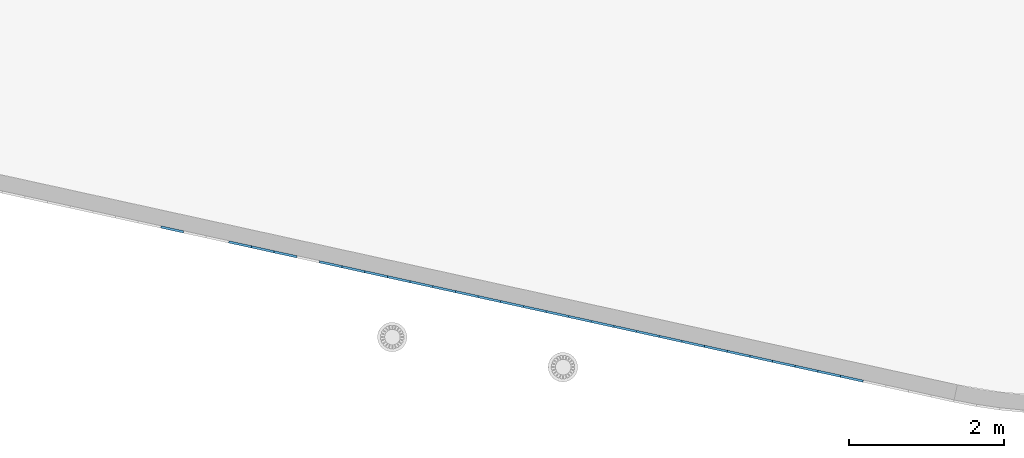
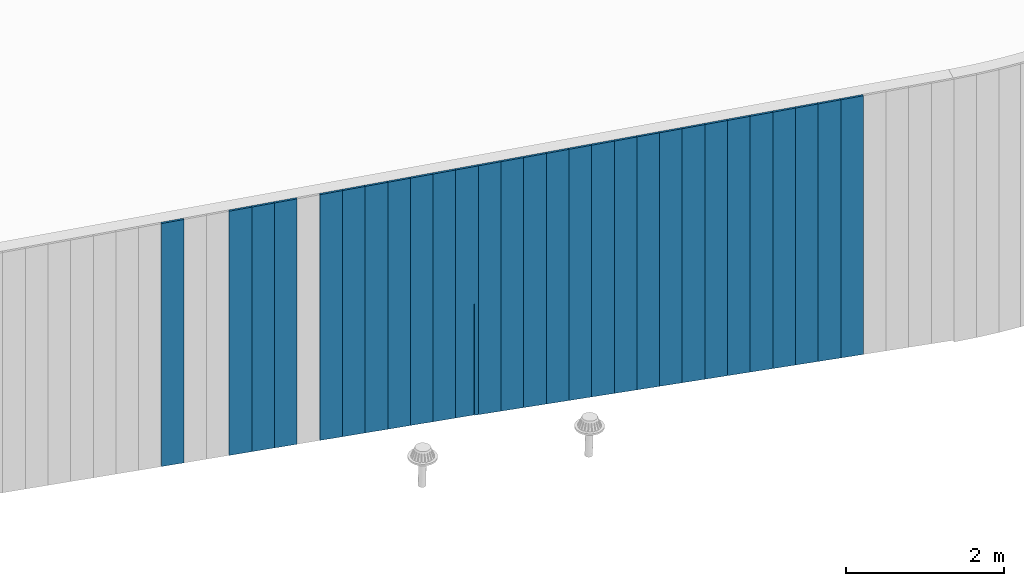
# One storey, part 5 of 18: 28 plates, 1 element without a shape of its own.
"""IFC2X3 building model written with IfcOpenShell, lengths in centimetres."""

from ifc_helpers import new_model, entity, si_unit, converted_unit, derived_unit, direction, frame, origin, place, context, subcontext, project, spatial, polyline, outline, extrude, source, transform, mapped, material, layer, layer_set, layer_usage, type_object, type_shapes, element, aggregate, save


model = new_model("IFC2X3")

# Units and contexts
model_context = context("Model", 3, precision=0.001, world=origin(), true_north=direction((6.12303176911189e-17, 1.0)))
body_context = subcontext(model_context, "Body", "Model", "MODEL_VIEW")
ifc_project = project(units=[si_unit("LENGTHUNIT", "METRE", prefix="CENTI"), si_unit("AREAUNIT", "SQUARE_METRE"), si_unit("VOLUMEUNIT", "CUBIC_METRE"), converted_unit("PLANEANGLEUNIT", "DEGREE", entity("IfcRatioMeasure", 0.0174532925199433), si_unit("PLANEANGLEUNIT", "RADIAN"), dimensions=[0, 0, 0, 0, 0, 0, 0]), si_unit("MASSUNIT", "GRAM", prefix="KILO"), derived_unit("MASSDENSITYUNIT", [(si_unit("MASSUNIT", "GRAM", prefix="KILO"), 1), (si_unit("LENGTHUNIT", "METRE"), -3)]), si_unit("TIMEUNIT", "SECOND"), si_unit("FREQUENCYUNIT", "HERTZ"), si_unit("THERMODYNAMICTEMPERATUREUNIT", "DEGREE_CELSIUS"), derived_unit("THERMALTRANSMITTANCEUNIT", [(si_unit("MASSUNIT", "GRAM", prefix="KILO"), 1), (si_unit("THERMODYNAMICTEMPERATUREUNIT", "KELVIN"), -1), (si_unit("TIMEUNIT", "SECOND"), -3)]), derived_unit("VOLUMETRICFLOWRATEUNIT", [(si_unit("LENGTHUNIT", "METRE"), 3), (si_unit("TIMEUNIT", "SECOND"), -1)]), si_unit("ELECTRICCURRENTUNIT", "AMPERE"), si_unit("ELECTRICVOLTAGEUNIT", "VOLT"), si_unit("POWERUNIT", "WATT"), si_unit("FORCEUNIT", "NEWTON", prefix="KILO"), si_unit("ILLUMINANCEUNIT", "LUX"), si_unit("LUMINOUSFLUXUNIT", "LUMEN"), si_unit("LUMINOUSINTENSITYUNIT", "CANDELA"), derived_unit("USERDEFINED", [(si_unit("MASSUNIT", "GRAM", prefix="KILO"), -1), (si_unit("LENGTHUNIT", "METRE"), -2), (si_unit("TIMEUNIT", "SECOND"), 3), (si_unit("LUMINOUSFLUXUNIT", "LUMEN"), 1)]), derived_unit("LINEARVELOCITYUNIT", [(si_unit("LENGTHUNIT", "METRE"), 1), (si_unit("TIMEUNIT", "SECOND"), -1)]), si_unit("PRESSUREUNIT", "PASCAL"), derived_unit("USERDEFINED", [(si_unit("LENGTHUNIT", "METRE"), -2), (si_unit("MASSUNIT", "GRAM", prefix="KILO"), 1), (si_unit("TIMEUNIT", "SECOND"), -2)])], contexts=[model_context])

# Site, building, storey
site_placement = place(None, origin())
site = spatial("IfcSite", under=ifc_project, at=site_placement, CompositionType="ELEMENT")
building_placement = place(site_placement, origin())
building = spatial("IfcBuilding", under=site, at=building_placement, CompositionType="ELEMENT")
storey_placement = place(building_placement, frame((0.0, 0.0, 1422.0)))
storey = spatial("IfcBuildingStorey", under=building, at=storey_placement, CompositionType="ELEMENT", Elevation=1422.0)

# Curtain wall, plates
curtain_wall_type = type_object("IfcCurtainWallType", PredefinedType="NOTDEFINED")
curtain_wall_placement = place(storey_placement, frame((0.0, 0.0, -1422.0)))
curtain_wall = element("IfcCurtainWall", 1, at=curtain_wall_placement, inside=storey, type_object=curtain_wall_type)
ifc_material = material()
ifc_layer = layer(ifc_material, 3.0)
ifc_layer_set = layer_set([ifc_layer])
ifc_layer_usage_1 = layer_usage(ifc_layer_set, "AXIS3", "POSITIVE", 0.0492125984251968)
plate_type_1 = type_object("IfcPlateType", Name="Panneau plein ST", PredefinedType="CURTAIN_PANEL", material=ifc_layer_set)
shared_shape_1 = source(origin(), body_context, "Body", "SweptSolid", [
    extrude(outline(polyline([(-199.557851196783, -15.0), (199.112195985161, -15.0), (199.112195985161, 15.0), (-198.666540773538, 15.0), (-199.557851196783, -15.0)])), frame((0.0, 0.0, 199.557851196783), z_axis=(0.0, 1.0, 0.0), x_axis=(0.0, 0.0, 1.0)), (0.0, 0.0, 1.0), 3.0),
])
type_shapes(plate_type_1, [shared_shape_1])
plate_1_placement = place(curtain_wall_placement, frame((8125.9712284793, 188.297410461873, 1023.32995281806), z_axis=(0.0, 0.0, 1.0), x_axis=(-0.976731958442773, 0.214463706385357, 0.0)))
plate_1 = element("IfcPlate", 2, at=plate_1_placement, type_object=plate_type_1, material=ifc_layer_usage_1, ObjectType="Panneau plein ST", context=body_context, shape_type="MappedRepresentation", body=[
    mapped(shared_shape_1, transform((0.0, 0.0, 0.0), scale=1.0)),
])
ifc_layer_usage_2 = layer_usage(ifc_layer_set, "AXIS3", "POSITIVE", 0.0492125984251968)
plate_type_2 = type_object("IfcPlateType", Name="Panneau plein ST", PredefinedType="CURTAIN_PANEL", material=ifc_layer_set)
shared_shape_2 = source(origin(), body_context, "Body", "SweptSolid", [
    extrude(outline(polyline([(-199.112195985161, -15.0), (198.666540773538, -15.0), (198.666540773538, 15.0), (-198.220885561915, 15.0), (-199.112195985161, -15.0)])), frame((0.0, 0.0, 199.112195985161), z_axis=(0.0, 1.0, 0.0), x_axis=(0.0, 0.0, 1.0)), (0.0, 0.0, 1.0), 3.0),
])
type_shapes(plate_type_2, [shared_shape_2])
plate_2_placement = place(curtain_wall_placement, frame((8096.66926972602, 194.731321653434, 1024.2212632413), z_axis=(0.0, 0.0, 1.0), x_axis=(-0.976731958442773, 0.214463706385357, 0.0)))
plate_2 = element("IfcPlate", 3, at=plate_2_placement, type_object=plate_type_2, material=ifc_layer_usage_2, ObjectType="Panneau plein ST", context=body_context, shape_type="MappedRepresentation", body=[
    mapped(shared_shape_2, transform((0.0, 0.0, 0.0), scale=1.0)),
])
ifc_layer_usage_3 = layer_usage(ifc_layer_set, "AXIS3", "POSITIVE", 0.0492125984251968)
plate_type_3 = type_object("IfcPlateType", Name="Panneau plein ST", PredefinedType="CURTAIN_PANEL", material=ifc_layer_set)
shared_shape_3 = source(origin(), body_context, "Body", "SweptSolid", [
    extrude(outline(polyline([(-198.666540773538, -15.0), (198.220885561915, -15.0), (198.220885561915, 15.0), (-197.775230350293, 15.0), (-198.666540773538, -15.0)])), frame((0.0, 0.0, 198.666540773538), z_axis=(0.0, 1.0, 0.0), x_axis=(0.0, 0.0, 1.0)), (0.0, 0.0, 1.0), 3.0),
])
type_shapes(plate_type_3, [shared_shape_3])
plate_3_placement = place(curtain_wall_placement, frame((8067.36731097274, 201.165232844995, 1025.11257366455), z_axis=(0.0, 0.0, 1.0), x_axis=(-0.976731958442773, 0.214463706385357, 0.0)))
plate_3 = element("IfcPlate", 4, at=plate_3_placement, type_object=plate_type_3, material=ifc_layer_usage_3, ObjectType="Panneau plein ST", context=body_context, shape_type="MappedRepresentation", body=[
    mapped(shared_shape_3, transform((0.0, 0.0, 0.0), scale=1.0)),
])
ifc_layer_usage_4 = layer_usage(ifc_layer_set, "AXIS3", "POSITIVE", 0.0492125984251968)
plate_type_4 = type_object("IfcPlateType", Name="Panneau plein ST", PredefinedType="CURTAIN_PANEL", material=ifc_layer_set)
shared_shape_4 = source(origin(), body_context, "Body", "SweptSolid", [
    extrude(outline(polyline([(-198.220885561915, -15.0), (197.775230350293, -15.0), (197.775230350293, 15.0), (-197.32957513867, 15.0), (-198.220885561915, -15.0)])), frame((0.0, 0.0, 198.220885561915), z_axis=(0.0, 1.0, 0.0), x_axis=(0.0, 0.0, 1.0)), (0.0, 0.0, 1.0), 3.0),
])
type_shapes(plate_type_4, [shared_shape_4])
plate_4_placement = place(curtain_wall_placement, frame((8038.06535221946, 207.599144036555, 1026.00388408779), z_axis=(0.0, 0.0, 1.0), x_axis=(-0.976731958442773, 0.214463706385357, 0.0)))
plate_4 = element("IfcPlate", 5, at=plate_4_placement, type_object=plate_type_4, material=ifc_layer_usage_4, ObjectType="Panneau plein ST", context=body_context, shape_type="MappedRepresentation", body=[
    mapped(shared_shape_4, transform((0.0, 0.0, 0.0), scale=1.0)),
])
ifc_layer_usage_5 = layer_usage(ifc_layer_set, "AXIS3", "POSITIVE", 0.0492125984251968)
plate_type_5 = type_object("IfcPlateType", Name="Panneau plein ST", PredefinedType="CURTAIN_PANEL", material=ifc_layer_set)
shared_shape_5 = source(origin(), body_context, "Body", "SweptSolid", [
    extrude(outline(polyline([(-197.775230350293, -15.0), (197.32957513867, -15.0), (197.32957513867, 15.0), (-196.883919927047, 15.0), (-197.775230350293, -15.0)])), frame((0.0, 0.0, 197.775230350293), z_axis=(0.0, 1.0, 0.0), x_axis=(0.0, 0.0, 1.0)), (0.0, 0.0, 1.0), 3.0),
])
type_shapes(plate_type_5, [shared_shape_5])
plate_5_placement = place(curtain_wall_placement, frame((8008.76339346617, 214.033055228116, 1026.89519451104), z_axis=(0.0, 0.0, 1.0), x_axis=(-0.976731958442773, 0.214463706385357, 0.0)))
plate_5 = element("IfcPlate", 6, at=plate_5_placement, type_object=plate_type_5, material=ifc_layer_usage_5, ObjectType="Panneau plein ST", context=body_context, shape_type="MappedRepresentation", body=[
    mapped(shared_shape_5, transform((0.0, 0.0, 0.0), scale=1.0)),
])
ifc_layer_usage_6 = layer_usage(ifc_layer_set, "AXIS3", "POSITIVE", 0.0492125984251968)
plate_type_6 = type_object("IfcPlateType", Name="Panneau plein ST", PredefinedType="CURTAIN_PANEL", material=ifc_layer_set)
shared_shape_6 = source(origin(), body_context, "Body", "SweptSolid", [
    extrude(outline(polyline([(-197.32957513867, -15.0), (196.883919927047, -15.0), (196.883919927047, 15.0), (-196.438264715425, 15.0), (-197.32957513867, -15.0)])), frame((0.0, 0.0, 197.32957513867), z_axis=(0.0, 1.0, 0.0), x_axis=(0.0, 0.0, 1.0)), (0.0, 0.0, 1.0), 3.0),
])
type_shapes(plate_type_6, [shared_shape_6])
plate_6_placement = place(curtain_wall_placement, frame((7979.46143471289, 220.466966419677, 1027.78650493428), z_axis=(0.0, 0.0, 1.0), x_axis=(-0.976731958442773, 0.214463706385357, 0.0)))
plate_6 = element("IfcPlate", 7, at=plate_6_placement, type_object=plate_type_6, material=ifc_layer_usage_6, ObjectType="Panneau plein ST", context=body_context, shape_type="MappedRepresentation", body=[
    mapped(shared_shape_6, transform((0.0, 0.0, 0.0), scale=1.0)),
])
ifc_layer_usage_7 = layer_usage(ifc_layer_set, "AXIS3", "POSITIVE", 0.0492125984251968)
plate_type_7 = type_object("IfcPlateType", Name="Panneau plein ST", PredefinedType="CURTAIN_PANEL", material=ifc_layer_set)
shared_shape_7 = source(origin(), body_context, "Body", "SweptSolid", [
    extrude(outline(polyline([(-196.883919927047, -15.0), (196.438264715425, -15.0), (196.438264715425, 15.0), (-195.992609503802, 15.0), (-196.883919927047, -15.0)])), frame((0.0, 0.0, 196.883919927047), z_axis=(0.0, 1.0, 0.0), x_axis=(0.0, 0.0, 1.0)), (0.0, 0.0, 1.0), 3.0),
])
type_shapes(plate_type_7, [shared_shape_7])
plate_7_placement = place(curtain_wall_placement, frame((7950.15947595961, 226.900877611237, 1028.67781535753), z_axis=(0.0, 0.0, 1.0), x_axis=(-0.976731958442773, 0.214463706385357, 0.0)))
plate_7 = element("IfcPlate", 8, at=plate_7_placement, type_object=plate_type_7, material=ifc_layer_usage_7, ObjectType="Panneau plein ST", context=body_context, shape_type="MappedRepresentation", body=[
    mapped(shared_shape_7, transform((0.0, 0.0, 0.0), scale=1.0)),
])
ifc_layer_usage_8 = layer_usage(ifc_layer_set, "AXIS3", "POSITIVE", 0.0492125984251968)
plate_type_8 = type_object("IfcPlateType", Name="Panneau plein ST", PredefinedType="CURTAIN_PANEL", material=ifc_layer_set)
shared_shape_8 = source(origin(), body_context, "Body", "SweptSolid", [
    extrude(outline(polyline([(-196.438264715425, -15.0), (195.992609503802, -15.0), (195.992609503802, 15.0), (-195.546954292179, 15.0), (-196.438264715425, -15.0)])), frame((0.0, 0.0, 196.438264715425), z_axis=(0.0, 1.0, 0.0), x_axis=(0.0, 0.0, 1.0)), (0.0, 0.0, 1.0), 3.0),
])
type_shapes(plate_type_8, [shared_shape_8])
plate_8_placement = place(curtain_wall_placement, frame((7920.85751720632, 233.334788802798, 1029.56912578077), z_axis=(0.0, 0.0, 1.0), x_axis=(-0.976731958442773, 0.214463706385357, 0.0)))
plate_8 = element("IfcPlate", 9, at=plate_8_placement, type_object=plate_type_8, material=ifc_layer_usage_8, ObjectType="Panneau plein ST", context=body_context, shape_type="MappedRepresentation", body=[
    mapped(shared_shape_8, transform((0.0, 0.0, 0.0), scale=1.0)),
])
ifc_layer_usage_9 = layer_usage(ifc_layer_set, "AXIS3", "POSITIVE", 0.0492125984251968)
plate_type_9 = type_object("IfcPlateType", Name="Panneau plein ST", PredefinedType="CURTAIN_PANEL", material=ifc_layer_set)
shared_shape_9 = source(origin(), body_context, "Body", "SweptSolid", [
    extrude(outline(polyline([(-195.992609503802, -15.0), (195.546954292179, -15.0), (195.546954292179, 15.0), (-195.101299080557, 15.0), (-195.992609503802, -15.0)])), frame((0.0, 0.0, 195.992609503802), z_axis=(0.0, 1.0, 0.0), x_axis=(0.0, 0.0, 1.0)), (0.0, 0.0, 1.0), 3.0),
])
type_shapes(plate_type_9, [shared_shape_9])
plate_9_placement = place(curtain_wall_placement, frame((7891.55555845304, 239.768699994359, 1030.46043620402), z_axis=(0.0, 0.0, 1.0), x_axis=(-0.976731958442773, 0.214463706385357, 0.0)))
plate_9 = element("IfcPlate", 10, at=plate_9_placement, type_object=plate_type_9, material=ifc_layer_usage_9, ObjectType="Panneau plein ST", context=body_context, shape_type="MappedRepresentation", body=[
    mapped(shared_shape_9, transform((0.0, 0.0, 0.0), scale=1.0)),
])
ifc_layer_usage_10 = layer_usage(ifc_layer_set, "AXIS3", "POSITIVE", 0.0492125984251968)
plate_type_10 = type_object("IfcPlateType", Name="Panneau plein ST", PredefinedType="CURTAIN_PANEL", material=ifc_layer_set)
shared_shape_10 = source(origin(), body_context, "Body", "SweptSolid", [
    extrude(outline(polyline([(-195.546954292179, -15.0), (195.101299080556, -15.0), (195.101299080556, 15.0), (-194.655643868934, 15.0), (-195.546954292179, -15.0)])), frame((0.0, 0.0, 195.546954292179), z_axis=(0.0, 1.0, 0.0), x_axis=(0.0, 0.0, 1.0)), (0.0, 0.0, 1.0), 3.0),
])
type_shapes(plate_type_10, [shared_shape_10])
plate_10_placement = place(curtain_wall_placement, frame((7862.25359969975, 246.20261118592, 1031.35174662726), z_axis=(0.0, 0.0, 1.0), x_axis=(-0.976731958442773, 0.214463706385357, 0.0)))
plate_10 = element("IfcPlate", 11, at=plate_10_placement, type_object=plate_type_10, material=ifc_layer_usage_10, ObjectType="Panneau plein ST", context=body_context, shape_type="MappedRepresentation", body=[
    mapped(shared_shape_10, transform((0.0, 0.0, 0.0), scale=1.0)),
])
ifc_layer_usage_11 = layer_usage(ifc_layer_set, "AXIS3", "POSITIVE", 0.0492125984251968)
plate_type_11 = type_object("IfcPlateType", Name="Panneau plein ST", PredefinedType="CURTAIN_PANEL", material=ifc_layer_set)
shared_shape_11 = source(origin(), body_context, "Body", "SweptSolid", [
    extrude(outline(polyline([(-195.101299080556, -15.0), (194.655643868934, -15.0), (194.655643868934, 15.0), (-194.209988657311, 15.0), (-195.101299080556, -15.0)])), frame((0.0, 0.0, 195.101299080556), z_axis=(0.0, 1.0, 0.0), x_axis=(0.0, 0.0, 1.0)), (0.0, 0.0, 1.0), 3.0),
])
type_shapes(plate_type_11, [shared_shape_11])
plate_11_placement = place(curtain_wall_placement, frame((7832.95164094647, 252.63652237748, 1032.24305705051), z_axis=(0.0, 0.0, 1.0), x_axis=(-0.976731958442773, 0.214463706385357, 0.0)))
plate_11 = element("IfcPlate", 12, at=plate_11_placement, type_object=plate_type_11, material=ifc_layer_usage_11, ObjectType="Panneau plein ST", context=body_context, shape_type="MappedRepresentation", body=[
    mapped(shared_shape_11, transform((0.0, 0.0, 0.0), scale=1.0)),
])
ifc_layer_usage_12 = layer_usage(ifc_layer_set, "AXIS3", "POSITIVE", 0.0492125984251968)
plate_type_12 = type_object("IfcPlateType", Name="Panneau plein ST", PredefinedType="CURTAIN_PANEL", material=ifc_layer_set)
shared_shape_12 = source(origin(), body_context, "Body", "SweptSolid", [
    extrude(outline(polyline([(-194.655643868934, -15.0), (194.209988657311, -15.0), (194.209988657311, 15.0), (-193.764333445688, 15.0), (-194.655643868934, -15.0)])), frame((0.0, 0.0, 194.655643868934), z_axis=(0.0, 1.0, 0.0), x_axis=(0.0, 0.0, 1.0)), (0.0, 0.0, 1.0), 3.0),
])
type_shapes(plate_type_12, [shared_shape_12])
plate_12_placement = place(curtain_wall_placement, frame((7803.64968219319, 259.070433569041, 1033.13436747376), z_axis=(0.0, 0.0, 1.0), x_axis=(-0.976731958442773, 0.214463706385357, 0.0)))
plate_12 = element("IfcPlate", 13, at=plate_12_placement, type_object=plate_type_12, material=ifc_layer_usage_12, ObjectType="Panneau plein ST", context=body_context, shape_type="MappedRepresentation", body=[
    mapped(shared_shape_12, transform((0.0, 0.0, 0.0), scale=1.0)),
])
ifc_layer_usage_13 = layer_usage(ifc_layer_set, "AXIS3", "POSITIVE", 0.0492125984251968)
plate_type_13 = type_object("IfcPlateType", Name="Panneau plein ST", PredefinedType="CURTAIN_PANEL", material=ifc_layer_set)
shared_shape_13 = source(origin(), body_context, "Body", "SweptSolid", [
    extrude(outline(polyline([(-194.209988657311, -15.0), (193.764333445688, -15.0), (193.764333445688, 15.0), (-193.318678234066, 15.0), (-194.209988657311, -15.0)])), frame((0.0, 0.0, 194.209988657311), z_axis=(0.0, 1.0, 0.0), x_axis=(0.0, 0.0, 1.0)), (0.0, 0.0, 1.0), 3.0),
])
type_shapes(plate_type_13, [shared_shape_13])
plate_13_placement = place(curtain_wall_placement, frame((7774.34772343991, 265.504344760602, 1034.025677897), z_axis=(0.0, 0.0, 1.0), x_axis=(-0.976731958442773, 0.214463706385357, 0.0)))
plate_13 = element("IfcPlate", 14, at=plate_13_placement, type_object=plate_type_13, material=ifc_layer_usage_13, ObjectType="Panneau plein ST", context=body_context, shape_type="MappedRepresentation", body=[
    mapped(shared_shape_13, transform((0.0, 0.0, 0.0), scale=1.0)),
])
ifc_layer_usage_14 = layer_usage(ifc_layer_set, "AXIS3", "POSITIVE", 0.0492125984251968)
plate_type_14 = type_object("IfcPlateType", Name="Panneau plein ST", PredefinedType="CURTAIN_PANEL", material=ifc_layer_set)
shared_shape_14 = source(origin(), body_context, "Body", "SweptSolid", [
    extrude(outline(polyline([(-193.764333445689, -15.0), (193.318678234066, -15.0), (193.318678234066, 15.0), (-192.873023022443, 15.0), (-193.764333445689, -15.0)])), frame((0.0, 0.0, 193.764333445689), z_axis=(0.0, 1.0, 0.0), x_axis=(0.0, 0.0, 1.0)), (0.0, 0.0, 1.0), 3.0),
])
type_shapes(plate_type_14, [shared_shape_14])
plate_14_placement = place(curtain_wall_placement, frame((7745.04576468662, 271.938255952162, 1034.91698832025), z_axis=(0.0, 0.0, 1.0), x_axis=(-0.976731958442773, 0.214463706385357, 0.0)))
plate_14 = element("IfcPlate", 15, at=plate_14_placement, type_object=plate_type_14, material=ifc_layer_usage_14, ObjectType="Panneau plein ST", context=body_context, shape_type="MappedRepresentation", body=[
    mapped(shared_shape_14, transform((0.0, 0.0, 0.0), scale=1.0)),
])
ifc_layer_usage_15 = layer_usage(ifc_layer_set, "AXIS3", "POSITIVE", 0.0492125984251968)
plate_type_15 = type_object("IfcPlateType", Name="Panneau plein ST", PredefinedType="CURTAIN_PANEL", material=ifc_layer_set)
shared_shape_15 = source(origin(), body_context, "Body", "SweptSolid", [
    extrude(outline(polyline([(-193.318678234066, -15.0), (192.873023022443, -15.0), (192.873023022443, 15.0), (-192.42736781082, 15.0), (-193.318678234066, -15.0)])), frame((0.0, 0.0, 193.318678234066), z_axis=(0.0, 1.0, 0.0), x_axis=(0.0, 0.0, 1.0)), (0.0, 0.0, 1.0), 3.0),
])
type_shapes(plate_type_15, [shared_shape_15])
plate_15_placement = place(curtain_wall_placement, frame((7715.74380593334, 278.372167143723, 1035.80829874349), z_axis=(0.0, 0.0, 1.0), x_axis=(-0.976731958442773, 0.214463706385357, 0.0)))
plate_15 = element("IfcPlate", 16, at=plate_15_placement, type_object=plate_type_15, material=ifc_layer_usage_15, ObjectType="Panneau plein ST", context=body_context, shape_type="MappedRepresentation", body=[
    mapped(shared_shape_15, transform((0.0, 0.0, 0.0), scale=1.0)),
])
ifc_layer_usage_16 = layer_usage(ifc_layer_set, "AXIS3", "POSITIVE", 0.0492125984251968)
plate_type_16 = type_object("IfcPlateType", Name="Panneau plein ST", PredefinedType="CURTAIN_PANEL", material=ifc_layer_set)
shared_shape_16 = source(origin(), body_context, "Body", "SweptSolid", [
    extrude(outline(polyline([(-192.873023022443, -15.0), (192.42736781082, -15.0), (192.42736781082, 15.0), (-191.981712599198, 15.0), (-192.873023022443, -15.0)])), frame((0.0, 0.0, 192.873023022443), z_axis=(0.0, 1.0, 0.0), x_axis=(0.0, 0.0, 1.0)), (0.0, 0.0, 1.0), 3.0),
])
type_shapes(plate_type_16, [shared_shape_16])
plate_16_placement = place(curtain_wall_placement, frame((7686.44184718006, 284.806078335284, 1036.69960916674), z_axis=(0.0, 0.0, 1.0), x_axis=(-0.976731958442773, 0.214463706385357, 0.0)))
plate_16 = element("IfcPlate", 17, at=plate_16_placement, type_object=plate_type_16, material=ifc_layer_usage_16, ObjectType="Panneau plein ST", context=body_context, shape_type="MappedRepresentation", body=[
    mapped(shared_shape_16, transform((0.0, 0.0, 0.0), scale=1.0)),
])
ifc_layer_usage_17 = layer_usage(ifc_layer_set, "AXIS3", "POSITIVE", 0.0492125984251968)
plate_type_17 = type_object("IfcPlateType", Name="Panneau plein ST", PredefinedType="CURTAIN_PANEL", material=ifc_layer_set)
shared_shape_17 = source(origin(), body_context, "Body", "SweptSolid", [
    extrude(outline(polyline([(-192.42736781082, -15.0), (191.981712599198, -15.0), (191.981712599198, 15.0), (-191.536057387575, 15.0), (-192.42736781082, -15.0)])), frame((0.0, 0.0, 192.42736781082), z_axis=(0.0, 1.0, 0.0), x_axis=(0.0, 0.0, 1.0)), (0.0, 0.0, 1.0), 3.0),
])
type_shapes(plate_type_17, [shared_shape_17])
plate_17_placement = place(curtain_wall_placement, frame((7657.13988842677, 291.239989526845, 1037.59091958998), z_axis=(0.0, 0.0, 1.0), x_axis=(-0.976731958442773, 0.214463706385357, 0.0)))
plate_17 = element("IfcPlate", 18, at=plate_17_placement, type_object=plate_type_17, material=ifc_layer_usage_17, ObjectType="Panneau plein ST", context=body_context, shape_type="MappedRepresentation", body=[
    mapped(shared_shape_17, transform((0.0, 0.0, 0.0), scale=1.0)),
])
ifc_layer_usage_18 = layer_usage(ifc_layer_set, "AXIS3", "POSITIVE", 0.0492125984251968)
plate_type_18 = type_object("IfcPlateType", Name="Panneau plein ST", PredefinedType="CURTAIN_PANEL", material=ifc_layer_set)
shared_shape_18 = source(origin(), body_context, "Body", "SweptSolid", [
    extrude(outline(polyline([(-139.021320228086, -10.2306533137287), (244.496449758687, -10.2306533137287), (244.496449758687, 19.7693466862705), (-137.805332782725, 19.7693466862704), (-138.285782509962, -4.2880125886244), (32.4964497586871, -4.28801258862545), (32.4964497586871, -5.25068078391656), (-138.873363513976, -5.25068078391713), (-139.021320228086, -10.2306533137287)])), frame((-4.76934668627161, 0.0, 139.021320228086), z_axis=(0.0, 1.0, 0.0), x_axis=(0.0, 0.0, 1.0)), (0.0, 0.0, 1.0), 3.0),
])
type_shapes(plate_type_18, [shared_shape_18])
plate_18_placement = place(curtain_wall_placement, frame((7627.83792967349, 297.673900718405, 1038.48223001323), z_axis=(0.0, 0.0, 1.0), x_axis=(-0.976731958442773, 0.214463706385357, 0.0)))
plate_18 = element("IfcPlate", 19, at=plate_18_placement, type_object=plate_type_18, material=ifc_layer_usage_18, ObjectType="Panneau plein ST", context=body_context, shape_type="MappedRepresentation", body=[
    mapped(shared_shape_18, transform((0.0, 0.0, 0.0), scale=1.0)),
])
ifc_layer_usage_19 = layer_usage(ifc_layer_set, "AXIS3", "POSITIVE", 0.0492125984251968)
plate_type_19 = type_object("IfcPlateType", Name="Panneau plein ST", PredefinedType="CURTAIN_PANEL", material=ifc_layer_set)
shared_shape_19 = source(origin(), body_context, "Body", "SweptSolid", [
    extrude(outline(polyline([(-191.300673834665, -15.0), (191.001108706747, -15.0), (191.001108706747, 15.0), (-190.701543578829, 15.0), (-191.300673834665, -15.0)])), frame((0.0, 0.0, 191.300673834665), z_axis=(0.0, 1.0, 0.0), x_axis=(0.0, 0.0, 1.0)), (0.0, 0.0, 1.0), 3.0),
])
type_shapes(plate_type_19, [shared_shape_19])
plate_19_placement = place(curtain_wall_placement, frame((7598.53597092021, 304.107811909966, 1039.69821745859), z_axis=(0.0, 0.0, 1.0), x_axis=(-0.976731958442773, 0.214463706385357, 0.0)))
plate_19 = element("IfcPlate", 20, at=plate_19_placement, type_object=plate_type_19, material=ifc_layer_usage_19, ObjectType="Panneau plein ST", context=body_context, shape_type="MappedRepresentation", body=[
    mapped(shared_shape_19, transform((0.0, 0.0, 0.0), scale=1.0)),
])
ifc_layer_usage_20 = layer_usage(ifc_layer_set, "AXIS3", "POSITIVE", 0.0492125984251968)
plate_type_20 = type_object("IfcPlateType", Name="Panneau plein ST", PredefinedType="CURTAIN_PANEL", material=ifc_layer_set)
shared_shape_20 = source(origin(), body_context, "Body", "SweptSolid", [
    extrude(outline(polyline([(-191.001108706747, -15.0), (190.701543578829, -15.0), (190.701543578829, 15.0), (-190.401978450911, 15.0), (-191.001108706747, -15.0)])), frame((0.0, 0.0, 191.001108706747), z_axis=(0.0, 1.0, 0.0), x_axis=(0.0, 0.0, 1.0)), (0.0, 0.0, 1.0), 3.0),
])
type_shapes(plate_type_20, [shared_shape_20])
plate_20_placement = place(curtain_wall_placement, frame((7569.23401216692, 310.541723101526, 1040.29734771442), z_axis=(0.0, 0.0, 1.0), x_axis=(-0.976731958442773, 0.214463706385357, 0.0)))
plate_20 = element("IfcPlate", 21, at=plate_20_placement, type_object=plate_type_20, material=ifc_layer_usage_20, ObjectType="Panneau plein ST", context=body_context, shape_type="MappedRepresentation", body=[
    mapped(shared_shape_20, transform((0.0, 0.0, 0.0), scale=1.0)),
])
ifc_layer_usage_21 = layer_usage(ifc_layer_set, "AXIS3", "POSITIVE", 0.0492125984251968)
plate_type_21 = type_object("IfcPlateType", Name="Panneau plein ST", PredefinedType="CURTAIN_PANEL", material=ifc_layer_set)
shared_shape_21 = source(origin(), body_context, "Body", "SweptSolid", [
    extrude(outline(polyline([(-190.701543578829, -15.0), (190.401978450911, -15.0), (190.401978450911, 15.0), (-190.102413322993, 15.0), (-190.701543578829, -15.0)])), frame((0.0, 0.0, 190.701543578829), z_axis=(0.0, 1.0, 0.0), x_axis=(0.0, 0.0, 1.0)), (0.0, 0.0, 1.0), 3.0),
])
type_shapes(plate_type_21, [shared_shape_21])
plate_21_placement = place(curtain_wall_placement, frame((7539.93205341364, 316.975634293087, 1040.89647797026), z_axis=(0.0, 0.0, 1.0), x_axis=(-0.976731958442773, 0.214463706385357, 0.0)))
plate_21 = element("IfcPlate", 22, at=plate_21_placement, type_object=plate_type_21, material=ifc_layer_usage_21, ObjectType="Panneau plein ST", context=body_context, shape_type="MappedRepresentation", body=[
    mapped(shared_shape_21, transform((0.0, 0.0, 0.0), scale=1.0)),
])
ifc_layer_usage_22 = layer_usage(ifc_layer_set, "AXIS3", "POSITIVE", 0.0492125984251968)
plate_type_22 = type_object("IfcPlateType", Name="Panneau plein ST", PredefinedType="CURTAIN_PANEL", material=ifc_layer_set)
shared_shape_22 = source(origin(), body_context, "Body", "SweptSolid", [
    extrude(outline(polyline([(-190.401978450911, -15.0), (190.102413322993, -15.0), (190.102413322993, 15.0), (-189.802848195075, 15.0), (-190.401978450911, -15.0)])), frame((0.0, 0.0, 190.401978450911), z_axis=(0.0, 1.0, 0.0), x_axis=(0.0, 0.0, 1.0)), (0.0, 0.0, 1.0), 3.0),
])
type_shapes(plate_type_22, [shared_shape_22])
plate_22_placement = place(curtain_wall_placement, frame((7510.63009466036, 323.409545484648, 1041.4956082261), z_axis=(0.0, 0.0, 1.0), x_axis=(-0.976731958442773, 0.214463706385357, 0.0)))
plate_22 = element("IfcPlate", 23, at=plate_22_placement, type_object=plate_type_22, material=ifc_layer_usage_22, ObjectType="Panneau plein ST", context=body_context, shape_type="MappedRepresentation", body=[
    mapped(shared_shape_22, transform((0.0, 0.0, 0.0), scale=1.0)),
])
ifc_layer_usage_23 = layer_usage(ifc_layer_set, "AXIS3", "POSITIVE", 0.0492125984251968)
plate_type_23 = type_object("IfcPlateType", Name="Panneau plein ST", PredefinedType="CURTAIN_PANEL", material=ifc_layer_set)
shared_shape_23 = source(origin(), body_context, "Body", "SweptSolid", [
    extrude(outline(polyline([(-190.102413322993, -15.0), (189.802848195075, -15.0), (189.802848195075, 15.0), (-189.503283067157, 15.0), (-190.102413322993, -15.0)])), frame((0.0, 0.0, 190.102413322993), z_axis=(0.0, 1.0, 0.0), x_axis=(0.0, 0.0, 1.0)), (0.0, 0.0, 1.0), 3.0),
])
type_shapes(plate_type_23, [shared_shape_23])
plate_23_placement = place(curtain_wall_placement, frame((7481.32813590707, 329.843456676208, 1042.09473848193), z_axis=(0.0, 0.0, 1.0), x_axis=(-0.976731958442773, 0.214463706385357, 0.0)))
plate_23 = element("IfcPlate", 24, at=plate_23_placement, type_object=plate_type_23, material=ifc_layer_usage_23, ObjectType="Panneau plein ST", context=body_context, shape_type="MappedRepresentation", body=[
    mapped(shared_shape_23, transform((0.0, 0.0, 0.0), scale=1.0)),
])
ifc_layer_usage_24 = layer_usage(ifc_layer_set, "AXIS3", "POSITIVE", 0.0492125984251968)
plate_type_24 = type_object("IfcPlateType", Name="Panneau plein ST", PredefinedType="CURTAIN_PANEL", material=ifc_layer_set)
shared_shape_24 = source(origin(), body_context, "Body", "SweptSolid", [
    extrude(outline(polyline([(-189.802848195075, -15.0), (189.503283067157, -15.0), (189.503283067157, 15.0), (-189.203717939239, 15.0), (-189.802848195075, -15.0)])), frame((0.0, 0.0, 189.802848195075), z_axis=(0.0, 1.0, 0.0), x_axis=(0.0, 0.0, 1.0)), (0.0, 0.0, 1.0), 3.0),
])
type_shapes(plate_type_24, [shared_shape_24])
plate_24_placement = place(curtain_wall_placement, frame((7452.02617715379, 336.277367867769, 1042.69386873777), z_axis=(0.0, 0.0, 1.0), x_axis=(-0.976731958442773, 0.214463706385357, 0.0)))
plate_24 = element("IfcPlate", 25, at=plate_24_placement, type_object=plate_type_24, material=ifc_layer_usage_24, ObjectType="Panneau plein ST", context=body_context, shape_type="MappedRepresentation", body=[
    mapped(shared_shape_24, transform((0.0, 0.0, 0.0), scale=1.0)),
])
ifc_layer_usage_25 = layer_usage(ifc_layer_set, "AXIS3", "POSITIVE", 0.0492125984251968)
plate_type_25 = type_object("IfcPlateType", Name="Panneau plein ST", PredefinedType="CURTAIN_PANEL", material=ifc_layer_set)
shared_shape_25 = source(origin(), body_context, "Body", "SweptSolid", [
    extrude(outline(polyline([(-189.203717939239, -15.0), (188.904152811321, -15.0), (188.904152811321, 15.0), (-188.604587683403, 15.0), (-189.203717939239, -15.0)])), frame((0.0, 0.0, 189.203717939239), z_axis=(0.0, 1.0, 0.0), x_axis=(0.0, 0.0, 1.0)), (0.0, 0.0, 1.0), 3.0),
])
type_shapes(plate_type_25, [shared_shape_25])
plate_25_placement = place(curtain_wall_placement, frame((7393.42225964722, 349.145190250891, 1043.89212924944), z_axis=(0.0, 0.0, 1.0), x_axis=(-0.976731958442773, 0.214463706385357, 0.0)))
plate_25 = element("IfcPlate", 26, at=plate_25_placement, type_object=plate_type_25, material=ifc_layer_usage_25, ObjectType="Panneau plein ST", context=body_context, shape_type="MappedRepresentation", body=[
    mapped(shared_shape_25, transform((0.0, 0.0, 0.0), scale=1.0)),
])
ifc_layer_usage_26 = layer_usage(ifc_layer_set, "AXIS3", "POSITIVE", 0.0492125984251968)
plate_type_26 = type_object("IfcPlateType", Name="Panneau plein ST", PredefinedType="CURTAIN_PANEL", material=ifc_layer_set)
shared_shape_26 = source(origin(), body_context, "Body", "SweptSolid", [
    extrude(outline(polyline([(-188.904152811321, -15.0), (188.604587683403, -15.0), (188.604587683403, 15.0), (-188.305022555485, 15.0), (-188.904152811321, -15.0)])), frame((0.0, 0.0, 188.904152811321), z_axis=(0.0, 1.0, 0.0), x_axis=(0.0, 0.0, 1.0)), (0.0, 0.0, 1.0), 3.0),
])
type_shapes(plate_type_26, [shared_shape_26])
plate_26_placement = place(curtain_wall_placement, frame((7364.12030089394, 355.579101442451, 1044.49125950528), z_axis=(0.0, 0.0, 1.0), x_axis=(-0.976731958442773, 0.214463706385357, 0.0)))
plate_26 = element("IfcPlate", 27, at=plate_26_placement, type_object=plate_type_26, material=ifc_layer_usage_26, ObjectType="Panneau plein ST", context=body_context, shape_type="MappedRepresentation", body=[
    mapped(shared_shape_26, transform((0.0, 0.0, 0.0), scale=1.0)),
])
ifc_layer_usage_27 = layer_usage(ifc_layer_set, "AXIS3", "POSITIVE", 0.0492125984251968)
plate_type_27 = type_object("IfcPlateType", Name="Panneau plein ST", PredefinedType="CURTAIN_PANEL", material=ifc_layer_set)
shared_shape_27 = source(origin(), body_context, "Body", "SweptSolid", [
    extrude(outline(polyline([(-188.604587683403, -15.0), (188.305022555485, -15.0), (188.305022555485, 15.0), (-188.005457427567, 15.0), (-188.604587683403, -15.0)])), frame((0.0, 0.0, 188.604587683403), z_axis=(0.0, 1.0, 0.0), x_axis=(0.0, 0.0, 1.0)), (0.0, 0.0, 1.0), 3.0),
])
type_shapes(plate_type_27, [shared_shape_27])
plate_27_placement = place(curtain_wall_placement, frame((7334.81834214066, 362.013012634012, 1045.09038976111), z_axis=(0.0, 0.0, 1.0), x_axis=(-0.976731958442773, 0.214463706385357, 0.0)))
plate_27 = element("IfcPlate", 28, at=plate_27_placement, type_object=plate_type_27, material=ifc_layer_usage_27, ObjectType="Panneau plein ST", context=body_context, shape_type="MappedRepresentation", body=[
    mapped(shared_shape_27, transform((0.0, 0.0, 0.0), scale=1.0)),
])
ifc_layer_usage_28 = layer_usage(ifc_layer_set, "AXIS3", "POSITIVE", 0.0492125984251968)
plate_type_28 = type_object("IfcPlateType", Name="Panneau plein ST", PredefinedType="CURTAIN_PANEL", material=ifc_layer_set)
shared_shape_28 = source(origin(), body_context, "Body", "SweptSolid", [
    extrude(outline(polyline([(-187.705892299649, -15.0), (187.406327171731, -15.0), (187.406327171731, 15.0), (-187.106762043813, 15.0), (-187.705892299649, -15.0)])), frame((0.0, 0.0, 187.705892299649), z_axis=(0.0, 1.0, 0.0), x_axis=(0.0, 0.0, 1.0)), (0.0, 0.0, 1.0), 3.0),
])
type_shapes(plate_type_28, [shared_shape_28])
plate_28_placement = place(curtain_wall_placement, frame((7246.91246588081, 381.314746208694, 1046.88778052862), z_axis=(0.0, 0.0, 1.0), x_axis=(-0.976731958442773, 0.214463706385357, 0.0)))
plate_28 = element("IfcPlate", 29, at=plate_28_placement, type_object=plate_type_28, material=ifc_layer_usage_28, ObjectType="Panneau plein ST", context=body_context, shape_type="MappedRepresentation", body=[
    mapped(shared_shape_28, transform((0.0, 0.0, 0.0), scale=1.0)),
])
aggregate(curtain_wall, [plate_1, plate_2, plate_3, plate_4, plate_5, plate_6, plate_7, plate_8, plate_9, plate_10, plate_11, plate_12, plate_13, plate_14, plate_15, plate_16, plate_17, plate_18, plate_19, plate_20, plate_21, plate_22, plate_23, plate_24, plate_25, plate_26, plate_27, plate_28])

save(model, "model.ifc")
